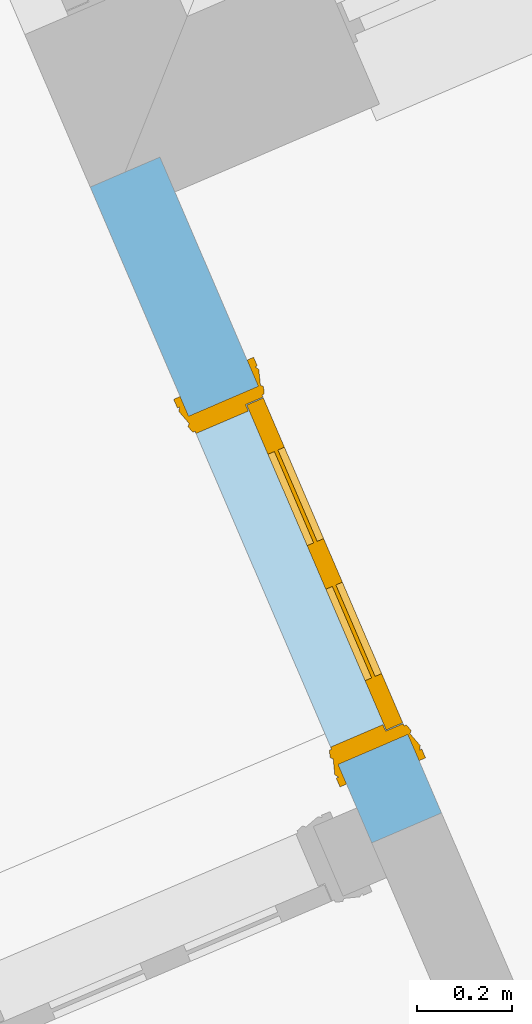
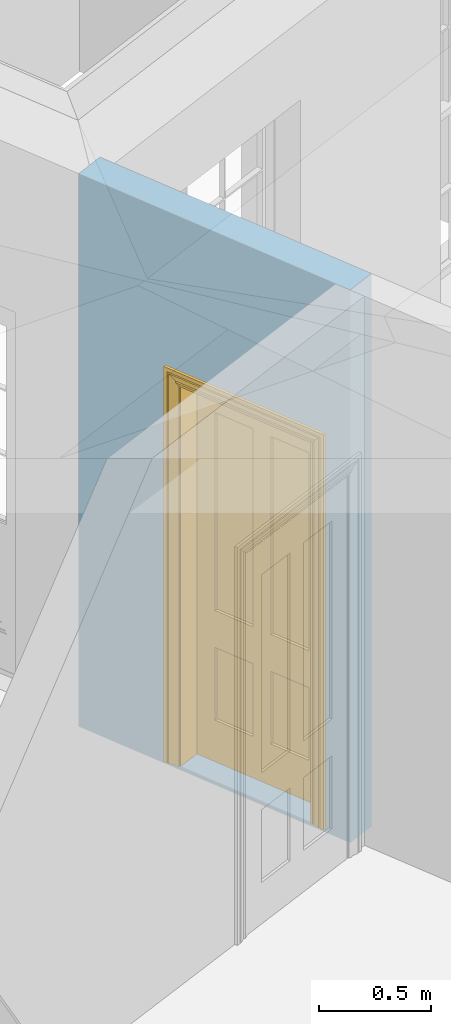
# One storey, part 9 of 19: 1 door, 1 opening, plus 1 element that does not belong to this part.
"""IFC2X3 building model written with IfcOpenShell, lengths in metres."""

from ifc_helpers import new_model, si_unit, frame, origin, place, context, subcontext, project, spatial, polyline, outline, extrude, faceted_brep, material, layer, layer_set, layer_usage, element, fill, save


model = new_model("IFC2X3")

# Units and contexts
model_context = context("Model", 3, world=origin())
body_context = subcontext(model_context, "Body", "Model", "MODEL_VIEW")
ifc_project = project(units=[si_unit("PLANEANGLEUNIT", "RADIAN"), si_unit("MASSUNIT", "GRAM", prefix="KILO"), si_unit("FORCEUNIT", "NEWTON", prefix="KILO"), si_unit("LENGTHUNIT", "METRE")], contexts=[model_context])

# Site, building, storey
site_placement = place(None, origin())
site = spatial("IfcSite", under=ifc_project, at=site_placement, CompositionType="ELEMENT")
building_placement = place(None, origin())
building = spatial("IfcBuilding", under=site, at=building_placement, Name="Building plot-0", CompositionType="ELEMENT")
storey_placement = place(None, origin())
storey = spatial("IfcBuildingStorey", under=building, at=storey_placement, Name="Floor 0", CompositionType="ELEMENT", Elevation=0.0)

# Wall, opening, door
ifc_material = material(Name="Masonry")
ifc_layer = layer(ifc_material, 0.16, ventilated=False)
ifc_layer_set = layer_set([ifc_layer], Name="My Wall")
ifc_layer_usage = layer_usage(ifc_layer_set, "AXIS2", "NEGATIVE", 0.08)
wall_placement = place(storey_placement, origin())
wall = element("IfcWallStandardCase", 1, at=wall_placement, inside=storey, material=ifc_layer_usage, Name="interior", context=body_context, shape_type="SweptSolid", body=[
    extrude(outline(polyline([(21.7409670474795, 29.9978953837467), (21.5939429625467, 29.9347770944031), (22.1880711776125, 28.5508492652236), (22.3350952625453, 28.6139675545672), (21.7409670474795, 29.9978953837467)])), origin(), (0.0, 0.0, 1.0), 3.0),
])
opening_placement = place(storey_placement, frame((0.0, 0.0, 0.02)))
opening = element("IfcOpeningElement", 2, at=opening_placement, cuts=wall, Name="Opening", ObjectType="Opening", context=body_context, shape_type="SweptSolid", body=[
    extrude(outline(polyline([(21.8014716553829, 29.4513717854372), (22.1170631021009, 28.716251360773), (22.2640871870338, 28.7793696501166), (21.9484957403157, 29.5144900747808), (21.8014716553829, 29.4513717854372)])), origin(), (0.0, 0.0, 1.0), 2.1),
])
door_placement = place(storey_placement, frame((21.8749836978493, 29.482930930109, 0.02), z_axis=(0.0, 0.0, 1.0), x_axis=(0.315591446718052, -0.735120424664157, 0.0)))
door = element("IfcDoor", 3, at=door_placement, inside=storey, Name="toilet inside door", OverallHeight=2.1, OverallWidth=0.8, context=body_context, shape_type="Brep", held_by="IfcProductRepresentation", body=[
    faceted_brep([(0.773, 0.08, 1.895), (0.66, 0.08, 1.895), (0.66, 0.08, 2.073), (0.773, 0.08, 2.073), (0.773, 0.08, 0.82), (0.66, 0.08, 0.82), (0.45, 0.08, 1.895), (0.45, 0.08, 2.073), (0.773, 0.08, 0.62), (0.66, 0.08, 0.62), (0.66, 0.065, 0.82), (0.66, 0.065, 1.895), (0.45, 0.065, 1.895), (0.35, 0.08, 1.895), (0.35, 0.08, 2.073), (0.773, 0.08, 0.225), (0.66, 0.08, 0.225), (0.45, 0.08, 0.62), (0.45, 0.08, 0.82), (0.45, 0.065, 0.82), (0.35, 0.08, 0.82), (0.14, 0.08, 2.073), (0.14, 0.08, 1.895), (0.773, 0.08, 0.0), (0.66, 0.08, 0.0), (0.66, 0.065, 0.225), (0.66, 0.065, 0.62), (0.45, 0.065, 0.62), (0.35, 0.08, 0.62), (0.35, 0.065, 0.82), (0.35, 0.065, 1.895), (0.14, 0.065, 1.895), (0.027, 0.08, 2.073), (0.027, 0.08, 1.895), (0.773, 0.042, 0.0), (0.66, 0.042, 0.0), (0.45, 0.08, 0.0), (0.45, 0.08, 0.225), (0.45, 0.065, 0.225), (0.35, 0.08, 0.225), (0.14, 0.08, 0.82), (0.14, 0.08, 0.62), (0.14, 0.065, 0.82), (0.027, 0.08, 0.82), (0.773, 0.042, 0.225), (0.66, 0.042, 0.225), (0.45, 0.042, 0.0), (0.35, 0.08, 0.0), (0.35, 0.065, 0.225), (0.35, 0.065, 0.62), (0.14, 0.065, 0.62), (0.027, 0.08, 0.62), (0.773, 0.042, 0.62), (0.66, 0.042, 0.62), (0.45, 0.042, 0.225), (0.35, 0.042, 0.0), (0.14, 0.08, 0.225), (0.14, 0.08, 0.0), (0.14, 0.065, 0.225), (0.027, 0.08, 0.225), (0.773, 0.042, 0.82), (0.66, 0.042, 0.82), (0.66, 0.057, 0.62), (0.66, 0.057, 0.225), (0.45, 0.057, 0.225), (0.35, 0.042, 0.225), (0.14, 0.042, 0.0), (0.027, 0.08, 0.0), (0.773, 0.042, 1.895), (0.66, 0.042, 1.895), (0.45, 0.042, 0.62), (0.45, 0.042, 0.82), (0.45, 0.057, 0.62), (0.35, 0.042, 0.62), (0.14, 0.042, 0.225), (0.027, 0.042, 0.0), (0.773, 0.042, 2.073), (0.66, 0.042, 2.073), (0.66, 0.057, 1.895), (0.66, 0.057, 0.82), (0.45, 0.057, 0.82), (0.35, 0.042, 0.82), (0.35, 0.057, 0.62), (0.35, 0.057, 0.225), (0.14, 0.057, 0.225), (0.027, 0.042, 0.225), (0.45, 0.042, 1.895), (0.45, 0.042, 2.073), (0.45, 0.057, 1.895), (0.35, 0.042, 1.895), (0.14, 0.042, 0.82), (0.14, 0.042, 0.62), (0.14, 0.057, 0.62), (0.027, 0.042, 0.62), (0.35, 0.042, 2.073), (0.35, 0.057, 1.895), (0.35, 0.057, 0.82), (0.14, 0.057, 0.82), (0.027, 0.042, 0.82), (0.14, 0.042, 2.073), (0.14, 0.042, 1.895), (0.14, 0.057, 1.895), (0.027, 0.042, 1.895), (0.027, 0.042, 2.073), (0.02, 0.085, 0.0), (0.005, 0.09, 0.0), (0.005, 0.09, 2.095), (0.02, 0.085, 2.08), (0.02, 0.08, 0.0), (0.0, 0.085, 0.0), (0.0, 0.085, 2.1), (0.795, 0.09, 2.095), (0.78, 0.085, 2.08), (0.02, 0.08, 2.08), (0.0, 0.08, 0.0), (-0.032, 0.095, 0.0), (-0.032, 0.095, 2.132), (0.8, 0.085, 2.1), (0.795, 0.09, 0.0), (0.78, 0.085, 0.0), (0.78, 0.08, 2.08), (0.04, 0.04, 0.0), (0.025, 0.04, 0.0), (0.025, 0.04, 2.075), (0.04, 0.04, 2.06), (-0.04, 0.09, 0.0), (-0.04, 0.09, 2.14), (0.832, 0.095, 2.132), (0.8, 0.085, 0.0), (0.78, 0.08, 0.0), (0.8, 0.08, 0.0), (0.86, 0.08, 0.0), (0.86, 0.08, 2.16), (0.8, 0.08, 2.1), (-0.06, 0.08, 2.16), (0.0, 0.08, 2.1), (-0.06, 0.08, 0.0), (-0.04, 0.095, 0.0), (-0.04, 0.095, 2.14), (0.84, 0.09, 2.14), (0.832, 0.095, 0.0), (0.84, 0.09, 0.0), (0.86, 0.095, 0.0), (0.86, 0.095, 2.16), (-0.06, 0.095, 2.16), (-0.06, 0.095, 0.0), (0.84, 0.095, 0.0), (0.84, 0.095, 2.14), (-0.025, -0.095, 0.0), (-0.025, -0.09, 0.0), (-0.025, -0.09, 2.125), (-0.025, -0.095, 2.125), (-0.017, -0.095, 0.0), (-0.017, -0.095, 2.117), (0.825, -0.09, 2.125), (0.825, -0.095, 2.125), (0.825, -0.095, 0.0), (0.845, -0.095, 0.0), (-0.045, -0.095, 2.145), (-0.045, -0.095, 0.0), (0.845, -0.095, 2.145), (0.015, -0.085, 0.0), (0.015, -0.085, 2.085), (0.817, -0.095, 2.117), (0.825, -0.09, 0.0), (0.845, -0.08, 0.0), (0.845, -0.08, 2.145), (-0.045, -0.08, 2.145), (-0.045, -0.08, 0.0), (0.02, -0.09, 0.0), (0.02, -0.09, 2.08), (0.785, -0.085, 2.085), (0.817, -0.095, 0.0), (0.8, -0.08, 0.0), (0.8, -0.08, 2.1), (0.0, -0.08, 2.1), (0.0, -0.08, 0.0), (0.035, -0.085, 0.0), (0.035, -0.085, 2.065), (0.78, -0.09, 2.08), (0.785, -0.085, 0.0), (0.775, 0.04, 2.075), (0.76, 0.04, 2.06), (0.035, -0.08, 2.065), (0.035, -0.08, 0.0), (0.765, -0.085, 2.065), (0.78, -0.09, 0.0), (0.765, -0.08, 0.0), (0.765, -0.08, 2.065), (0.765, -0.085, 0.0), (0.04, -0.08, 2.06), (0.04, -0.08, 0.0), (0.76, -0.08, 2.06), (0.76, -0.08, 0.0), (0.76, 0.04, 0.0), (0.775, 0.04, 0.0), (0.025, 0.08, 0.0), (0.025, 0.08, 2.075), (0.775, 0.08, 0.0), (0.775, 0.08, 2.075)], [[[0, 1, 2, 3]], [[1, 0, 4, 5]], [[1, 6, 7, 2]], [[8, 9, 5, 4]], [[1, 5, 10, 11]], [[6, 1, 11, 12]], [[6, 13, 14, 7]], [[15, 16, 9, 8]], [[9, 17, 18, 5]], [[5, 18, 19, 10]], [[10, 19, 12, 11]], [[18, 6, 12, 19]], [[18, 20, 13, 6]], [[21, 14, 13, 22]], [[23, 24, 16, 15]], [[9, 16, 25, 26]], [[17, 9, 26, 27]], [[17, 28, 20, 18]], [[13, 20, 29, 30]], [[22, 13, 30, 31]], [[32, 21, 22, 33]], [[34, 35, 24, 23]], [[24, 36, 37, 16]], [[16, 37, 38, 25]], [[25, 38, 27, 26]], [[37, 17, 27, 38]], [[37, 39, 28, 17]], [[40, 20, 28, 41]], [[20, 40, 42, 29]], [[31, 30, 29, 42]], [[40, 22, 31, 42]], [[33, 22, 40, 43]], [[35, 34, 44, 45]], [[35, 46, 36, 24]], [[36, 47, 39, 37]], [[28, 39, 48, 49]], [[41, 28, 49, 50]], [[43, 40, 41, 51]], [[45, 44, 52, 53]], [[46, 35, 45, 54]], [[46, 55, 47, 36]], [[56, 39, 47, 57]], [[39, 56, 58, 48]], [[50, 49, 48, 58]], [[56, 41, 50, 58]], [[51, 41, 56, 59]], [[53, 52, 60, 61]], [[45, 53, 62, 63]], [[54, 45, 63, 64]], [[55, 46, 54, 65]], [[55, 66, 57, 47]], [[59, 56, 57, 67]], [[61, 60, 68, 69]], [[70, 53, 61, 71]], [[53, 70, 72, 62]], [[72, 64, 63, 62]], [[70, 54, 64, 72]], [[65, 54, 70, 73]], [[65, 74, 66, 55]], [[67, 57, 66, 75]], [[69, 68, 76, 77]], [[61, 69, 78, 79]], [[71, 61, 79, 80]], [[73, 70, 71, 81]], [[65, 73, 82, 83]], [[74, 65, 83, 84]], [[74, 85, 75, 66]], [[86, 69, 77, 87]], [[69, 86, 88, 78]], [[88, 80, 79, 78]], [[86, 71, 80, 88]], [[81, 71, 86, 89]], [[73, 81, 90, 91]], [[73, 91, 92, 82]], [[83, 82, 92, 84]], [[91, 74, 84, 92]], [[91, 93, 85, 74]], [[89, 86, 87, 94]], [[81, 89, 95, 96]], [[90, 81, 96, 97]], [[90, 98, 93, 91]], [[94, 99, 100, 89]], [[89, 100, 101, 95]], [[101, 97, 96, 95]], [[100, 90, 97, 101]], [[100, 102, 98, 90]], [[99, 103, 102, 100]], [[32, 103, 99, 21]], [[102, 103, 32, 33]], [[98, 102, 33, 43]], [[21, 99, 94, 14]], [[94, 87, 7, 14]], [[7, 87, 77, 2]], [[76, 3, 2, 77]], [[43, 51, 93, 98]], [[51, 59, 85, 93]], [[67, 75, 85, 59]], [[34, 23, 15, 44]], [[44, 15, 8, 52]], [[52, 8, 4, 60]], [[0, 68, 60, 4]], [[0, 3, 76, 68]], [[104, 105, 106, 107]], [[104, 108, 109, 105]], [[105, 109, 110, 106]], [[107, 106, 111, 112]], [[107, 113, 108, 104]], [[114, 109, 108]], [[109, 115, 116, 110]], [[106, 110, 117, 111]], [[112, 111, 118, 119]], [[113, 107, 112, 120]], [[121, 122, 123, 124]], [[115, 109, 114, 125]], [[115, 125, 126, 116]], [[110, 116, 127, 117]], [[111, 117, 128, 118]], [[118, 128, 129, 119]], [[120, 112, 119, 129]], [[130, 129, 128]], [[130, 131, 132, 133]], [[133, 132, 134, 135]], [[135, 134, 136, 114]], [[136, 125, 114]], [[125, 137, 138, 126]], [[116, 126, 139, 127]], [[117, 127, 140, 128]], [[141, 130, 128, 140]], [[131, 130, 141]], [[131, 142, 143, 132]], [[132, 143, 144, 134]], [[134, 144, 145, 136]], [[137, 125, 136, 145]], [[143, 142, 146]], [[143, 146, 147]], [[137, 145, 144]], [[143, 147, 138]], [[138, 137, 144]], [[143, 138, 144]], [[126, 138, 147, 139]], [[127, 139, 141, 140]], [[142, 131, 141, 146]], [[139, 147, 146, 141]], [[148, 149, 150, 151]], [[149, 152, 153, 150]], [[151, 150, 154, 155]], [[155, 156, 157]], [[158, 159, 148]], [[158, 148, 151]], [[155, 157, 160]], [[158, 151, 155]], [[155, 160, 158]], [[152, 161, 162, 153]], [[150, 153, 163, 154]], [[155, 154, 164, 156]], [[156, 164, 165, 157]], [[157, 165, 166, 160]], [[160, 166, 167, 158]], [[158, 167, 168, 159]], [[161, 169, 170, 162]], [[153, 162, 171, 163]], [[154, 163, 172, 164]], [[165, 164, 173]], [[165, 173, 174, 166]], [[166, 174, 175, 167]], [[167, 175, 176, 168]], [[169, 177, 178, 170]], [[162, 170, 179, 171]], [[163, 171, 180, 172]], [[172, 180, 173, 164]], [[124, 123, 181, 182]], [[183, 178, 177, 184]], [[170, 178, 185, 179]], [[171, 179, 186, 180]], [[187, 173, 180]], [[185, 188, 187, 189]], [[188, 185, 178, 183]], [[179, 185, 189, 186]], [[189, 187, 180, 186]], [[190, 183, 184, 191]], [[192, 188, 183, 190]], [[191, 184, 122, 121]], [[124, 190, 191, 121]], [[193, 187, 188, 192]], [[182, 192, 190, 124]], [[184, 176, 122]], [[194, 195, 187, 193]], [[192, 182, 194, 193]], [[161, 176, 184]], [[114, 108, 122, 176]], [[173, 187, 195]], [[152, 149, 176, 161]], [[169, 161, 184, 177]], [[196, 122, 108]], [[176, 175, 135, 114]], [[173, 195, 129, 130]], [[176, 149, 168]], [[123, 122, 196, 197]], [[196, 108, 113, 197]], [[175, 174, 133, 135]], [[198, 129, 195]], [[133, 174, 173, 130]], [[159, 168, 149, 148]], [[181, 123, 197, 199]], [[197, 113, 120, 199]], [[199, 120, 129, 198]], [[195, 181, 199, 198]], [[195, 194, 182, 181]]]),
])
fill(opening, door)

save(model, "model.ifc")
